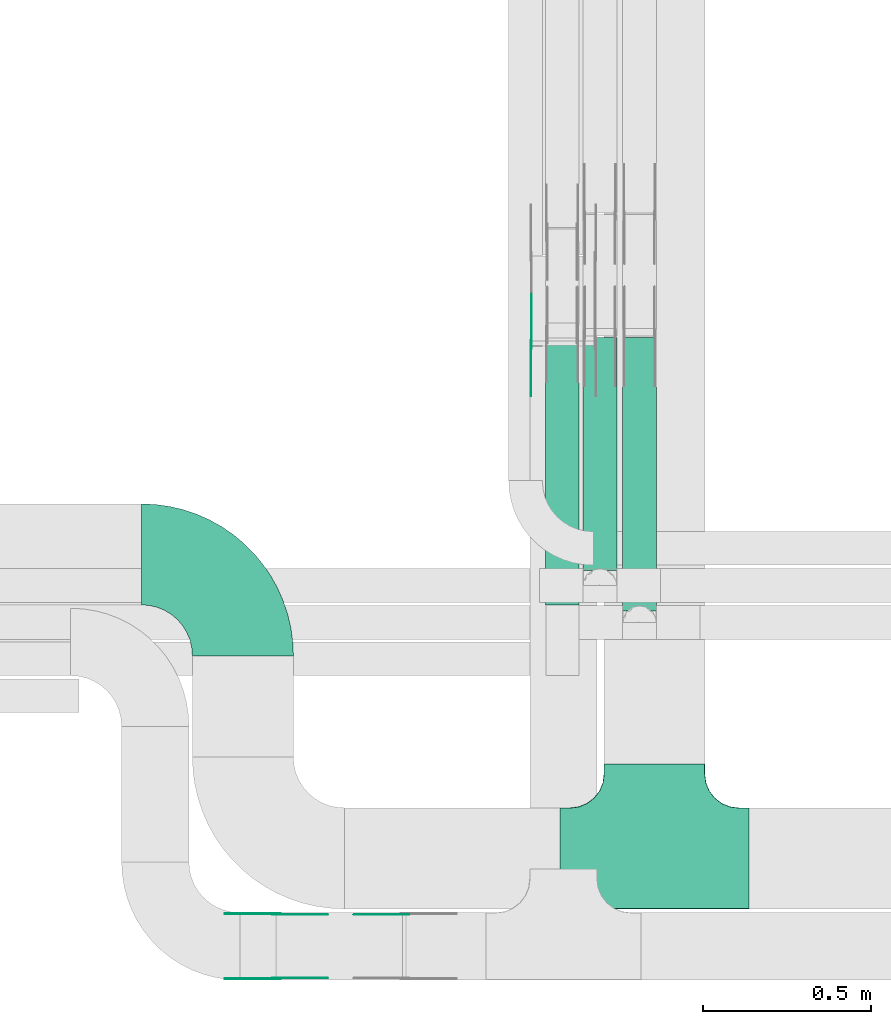
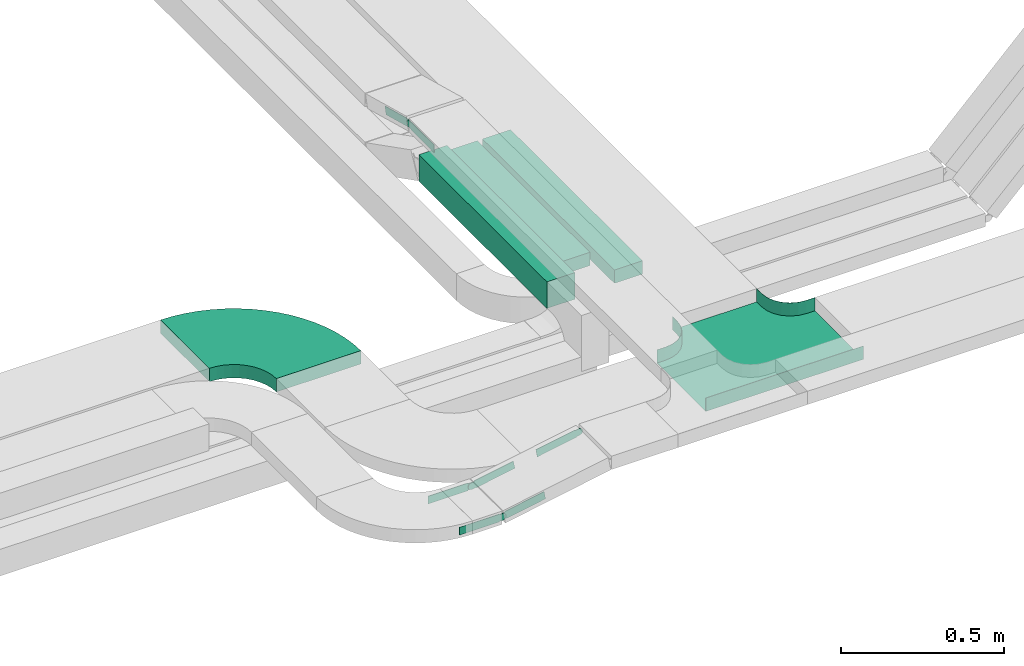
# One storey, part 14 of 19: 9 flow fittings, 3 flow segments.
"""IFC2X3 building model written with IfcOpenShell, lengths in millimetres."""

from ifc_helpers import new_model, entity, si_unit, converted_unit, derived_unit, direction, frame, frame_2d, origin, origin_2d_with_axis, place, context, subcontext, project, spatial, polyline, circle_curve, parameter, trimmed, segment, composite_curve, rectangle, outline, extrude, faceted_brep, source, transform, mapped, material, type_object, type_shapes, element, save


model = new_model("IFC2X3")

# Units and contexts
model_context = context("Model", 3, precision=0.01, world=origin(), true_north=direction((6.12303176911189e-17, 1.0)))
body_context = subcontext(model_context, "Body", "Model", "MODEL_VIEW")
ifc_project = project(units=[si_unit("LENGTHUNIT", "METRE", prefix="MILLI"), si_unit("AREAUNIT", "SQUARE_METRE"), si_unit("VOLUMEUNIT", "CUBIC_METRE"), converted_unit("PLANEANGLEUNIT", "DEGREE", entity("IfcRatioMeasure", 0.0174532925199433), si_unit("PLANEANGLEUNIT", "RADIAN"), dimensions=[0, 0, 0, 0, 0, 0, 0]), si_unit("MASSUNIT", "GRAM", prefix="KILO"), derived_unit("MASSDENSITYUNIT", [(si_unit("MASSUNIT", "GRAM", prefix="KILO"), 1), (si_unit("LENGTHUNIT", "METRE"), -3)]), derived_unit("MOMENTOFINERTIAUNIT", [(si_unit("LENGTHUNIT", "METRE"), 4)]), si_unit("TIMEUNIT", "SECOND"), si_unit("FREQUENCYUNIT", "HERTZ"), si_unit("THERMODYNAMICTEMPERATUREUNIT", "DEGREE_CELSIUS"), derived_unit("THERMALTRANSMITTANCEUNIT", [(si_unit("MASSUNIT", "GRAM", prefix="KILO"), 1), (si_unit("THERMODYNAMICTEMPERATUREUNIT", "KELVIN"), -1), (si_unit("TIMEUNIT", "SECOND"), -3)]), derived_unit("VOLUMETRICFLOWRATEUNIT", [(si_unit("LENGTHUNIT", "METRE"), 3), (si_unit("TIMEUNIT", "SECOND"), -1)]), derived_unit("MASSFLOWRATEUNIT", [(si_unit("MASSUNIT", "GRAM", prefix="KILO"), 1), (si_unit("TIMEUNIT", "SECOND"), -1)]), derived_unit("ROTATIONALFREQUENCYUNIT", [(si_unit("TIMEUNIT", "SECOND"), -1)]), si_unit("ELECTRICCURRENTUNIT", "AMPERE"), si_unit("ELECTRICVOLTAGEUNIT", "VOLT"), si_unit("POWERUNIT", "WATT"), si_unit("FORCEUNIT", "NEWTON", prefix="KILO"), si_unit("ILLUMINANCEUNIT", "LUX"), si_unit("LUMINOUSFLUXUNIT", "LUMEN"), si_unit("LUMINOUSINTENSITYUNIT", "CANDELA"), derived_unit("USERDEFINED", [(si_unit("MASSUNIT", "GRAM", prefix="KILO"), -1), (si_unit("LENGTHUNIT", "METRE"), -2), (si_unit("TIMEUNIT", "SECOND"), 3), (si_unit("LUMINOUSFLUXUNIT", "LUMEN"), 1)]), derived_unit("LINEARVELOCITYUNIT", [(si_unit("LENGTHUNIT", "METRE"), 1), (si_unit("TIMEUNIT", "SECOND"), -1)]), si_unit("PRESSUREUNIT", "PASCAL"), derived_unit("USERDEFINED", [(si_unit("LENGTHUNIT", "METRE"), -2), (si_unit("MASSUNIT", "GRAM", prefix="KILO"), 1), (si_unit("TIMEUNIT", "SECOND"), -2)]), derived_unit("LINEARFORCEUNIT", [(si_unit("MASSUNIT", "GRAM", prefix="KILO"), 1), (si_unit("LENGTHUNIT", "METRE"), 1), (si_unit("TIMEUNIT", "SECOND"), -2), (si_unit("LENGTHUNIT", "METRE"), -1)]), derived_unit("PLANARFORCEUNIT", [(si_unit("MASSUNIT", "GRAM", prefix="KILO"), 1), (si_unit("LENGTHUNIT", "METRE"), 1), (si_unit("TIMEUNIT", "SECOND"), -2), (si_unit("LENGTHUNIT", "METRE"), -2)])], contexts=[model_context])

# Site, building, storey
site_placement = place(None, origin())
site = spatial("IfcSite", under=ifc_project, at=site_placement, CompositionType="ELEMENT")
building_placement = place(site_placement, origin())
building = spatial("IfcBuilding", under=site, at=building_placement, CompositionType="ELEMENT")
storey_placement = place(building_placement, frame((0.0, 0.0, 12000.0)))
storey = spatial("IfcBuildingStorey", under=building, at=storey_placement, CompositionType="ELEMENT", Elevation=12000.0)

# Flow segments
cable_carrier_segment_type = type_object("IfcCableCarrierSegmentType", PredefinedType="CABLETRAYSEGMENT")
flow_segment_1_placement = place(storey_placement, frame((60138.97, 9727.13, 2655.0)))
element("IfcFlowSegment", 1, at=flow_segment_1_placement, inside=storey, type_object=cable_carrier_segment_type, context=body_context, shape_type="SweptSolid", body=[
    extrude(rectangle(XDim=788.027884581207, YDim=99.9999999999946, at=origin_2d_with_axis()), frame((50.0, 394.01, 0.0), z_axis=(0.0, 0.0, 1.0), x_axis=(0.0, -1.0, 0.0)), (0.0, 0.0, 1.0), 100.000000000001),
])
flow_segment_2_placement = place(storey_placement, frame((60250.78, 9829.12, 2680.0)))
element("IfcFlowSegment", 2, at=flow_segment_2_placement, inside=storey, type_object=cable_carrier_segment_type, context=body_context, shape_type="SweptSolid", body=[
    extrude(rectangle(XDim=692.037715986748, YDim=99.9999999999946, at=origin_2d_with_axis()), frame((50.0, 346.02, 0.0), z_axis=(0.0, 0.0, 1.0), x_axis=(0.0, -1.0, 0.0)), (0.0, 0.0, 1.0), 50.0000000000016),
])
flow_segment_3_placement = place(storey_placement, frame((60368.35, 9709.12, 2680.0)))
element("IfcFlowSegment", 3, at=flow_segment_3_placement, inside=storey, type_object=cable_carrier_segment_type, context=body_context, shape_type="SweptSolid", body=[
    extrude(rectangle(XDim=812.037715986744, YDim=99.9999999999946, at=origin_2d_with_axis()), frame((50.0, 406.02, 0.0), z_axis=(0.0, 0.0, 1.0), x_axis=(0.0, -1.0, 0.0)), (0.0, 0.0, 1.0), 50.0000000000016),
])

# Flow fittings
ifc_material_1 = material()
cable_carrier_fitting_type_1 = type_object("IfcCableCarrierFittingType", PredefinedType="NOTDEFINED", material=ifc_material_1)
shared_shape_1 = source(origin(), body_context, "Body", "Brep", [
    faceted_brep([(-153.41, -224.12, 25.0), (-150.0, -250.0, 25.0), (-150.0, -280.0, 25.0), (-149.2, -280.0, 25.0), (-149.2, -250.0, 25.0), (-152.63, -223.91, 25.0), (-162.7, -199.6, 25.0), (-178.72, -178.72, 25.0), (-199.6, -162.7, 25.0), (-223.91, -152.63, 25.0), (-250.0, -149.2, 25.0), (-280.0, -149.2, 25.0), (-280.0, -150.0, 25.0), (-250.0, -150.0, 25.0), (-224.12, -153.41, 25.0), (-200.0, -163.4, 25.0), (-179.29, -179.29, 25.0), (-163.4, -200.0, 25.0), (280.0, -150.0, 25.0), (280.0, -149.2, 25.0), (250.0, -149.2, 25.0), (223.91, -152.63, 25.0), (199.6, -162.7, 25.0), (178.72, -178.72, 25.0), (162.7, -199.6, 25.0), (152.63, -223.91, 25.0), (149.2, -250.0, 25.0), (149.2, -280.0, 25.0), (150.0, -280.0, 25.0), (150.0, -250.0, 25.0), (153.41, -224.12, 25.0), (163.4, -200.0, 25.0), (179.29, -179.29, 25.0), (200.0, -163.4, 25.0), (224.12, -153.41, 25.0), (250.0, -150.0, 25.0), (280.0, 149.2, 25.0), (280.0, 150.0, 25.0), (-280.0, 150.0, 25.0), (-280.0, 149.2, 25.0), (-280.0, -150.0, -25.0), (-280.0, 150.0, -25.0), (280.0, 150.0, -25.0), (280.0, -150.0, -25.0), (250.0, -150.0, -25.0), (224.12, -153.41, -25.0), (200.0, -163.4, -25.0), (179.29, -179.29, -25.0), (163.4, -200.0, -25.0), (153.41, -224.12, -25.0), (150.0, -250.0, -25.0), (150.0, -280.0, -25.0), (-150.0, -280.0, -25.0), (-150.0, -250.0, -25.0), (-153.41, -224.12, -25.0), (-163.4, -200.0, -25.0), (-179.29, -179.29, -25.0), (-200.0, -163.4, -25.0), (-224.12, -153.41, -25.0), (-250.0, -150.0, -25.0), (-150.0, -250.0, -24.2), (149.2, -280.0, -24.2), (-149.2, -280.0, -24.2), (-149.2, -250.0, -24.2), (-250.0, -149.2, -24.2), (-280.0, -149.2, -24.2), (280.0, -149.2, -24.2), (250.0, -149.2, -24.2), (-280.0, 149.2, -24.2), (-250.0, -150.0, -24.2), (250.0, -150.0, -24.2), (280.0, 149.2, -24.2), (149.2, -250.0, -24.2), (150.0, -250.0, -24.2), (-223.91, -152.63, -24.2), (-199.6, -162.7, -24.2), (-178.72, -178.72, -24.2), (-162.7, -199.6, -24.2), (-152.63, -223.91, -24.2), (152.63, -223.91, -24.2), (162.7, -199.6, -24.2), (178.72, -178.72, -24.2), (199.6, -162.7, -24.2), (223.91, -152.63, -24.2)], [[[0, 1, 2, 3, 4, 5, 6, 7, 8, 9, 10, 11, 12, 13, 14, 15, 16, 17]], [[18, 19, 20, 21, 22, 23, 24, 25, 26, 27, 28, 29, 30, 31, 32, 33, 34, 35]], [[36, 37, 38, 39]], [[40, 41, 42, 43, 44, 45, 46, 47, 48, 49, 50, 51, 52, 53, 54, 55, 56, 57, 58, 59]], [[2, 1, 60, 53, 52]], [[3, 2, 52, 51, 28, 27, 61, 62]], [[4, 3, 62, 63]], [[11, 10, 64, 65]], [[20, 19, 66, 67]], [[39, 38, 41, 40, 12, 11, 65, 68]], [[13, 12, 40, 59, 69]], [[18, 35, 70, 44, 43]], [[19, 18, 43, 42, 37, 36, 71, 66]], [[27, 26, 72, 61]], [[29, 28, 51, 50, 73]], [[38, 37, 42, 41]], [[36, 39, 68, 71]], [[68, 65, 64, 74, 75, 76, 77, 78, 63, 62, 61, 72, 79, 80, 81, 82, 83, 67, 66, 71]], [[14, 13, 69, 59, 58]], [[58, 57, 15, 14]], [[15, 57, 56, 16]], [[0, 17, 55, 54]], [[0, 54, 53, 60, 1]], [[55, 17, 16, 56]], [[5, 4, 63, 78]], [[6, 5, 78, 77]], [[7, 6, 77, 76]], [[8, 7, 76, 75]], [[9, 8, 75, 74]], [[10, 9, 74, 64]], [[21, 20, 67, 83]], [[22, 21, 83, 82]], [[23, 22, 82, 81]], [[81, 80, 24, 23]], [[24, 80, 79, 25]], [[79, 72, 26, 25]], [[30, 29, 73, 50, 49]], [[31, 30, 49, 48]], [[31, 48, 47, 32]], [[33, 32, 47, 46]], [[45, 34, 33, 46]], [[34, 45, 44, 70, 35]]]),
])
type_shapes(cable_carrier_fitting_type_1, [shared_shape_1])
flow_fitting_1_placement = place(storey_placement, frame((60462.55, 8974.99, 2825.0), z_axis=(0.0, 0.0, 1.0), x_axis=(-1.0, 0.0, 0.0)))
element("IfcFlowFitting", 4, at=flow_fitting_1_placement, inside=storey, type_object=cable_carrier_fitting_type_1, material=ifc_material_1, Name="470_DKC_S5_T", context=body_context, shape_type="MappedRepresentation", body=[
    mapped(shared_shape_1, transform((0.0, 0.0, 0.0), scale=1.0)),
])
cable_carrier_fitting_type_2 = type_object("IfcCableCarrierFittingType", Name="470_DKC_S5_Variable Angle Elbow 0-45:-", PredefinedType="NOTDEFINED", material=ifc_material_1)
shared_shape_2 = source(origin(), body_context, "Body", "SweptSolid", [
    extrude(outline(composite_curve([segment(polyline([(-150.75, -300.25), (-149.75, -300.25)]), True, "CONTINUOUS"), segment(trimmed(circle_curve(frame_2d((-149.75, 149.75), x_axis=(0.0, -1.0)), 450.0), [parameter(0.0)], [parameter(90.0000000000001)], True, "PARAMETER"), True, "CONTINUOUS"), segment(polyline([(300.25, 149.75), (300.25, 150.75)]), True, "CONTINUOUS"), segment(polyline([(300.25, 150.75), (0.25, 150.75)]), True, "CONTINUOUS"), segment(polyline([(0.25, 150.75), (0.25, 149.75)]), True, "CONTINUOUS"), segment(trimmed(circle_curve(frame_2d((-149.75, 149.75), x_axis=(0.0, -1.0)), 150.0), [parameter(0.0)], [parameter(90.0000000000001)], True, "PARAMETER"), False, "CONTINUOUS"), segment(polyline([(-149.75, -0.25), (-150.75, -0.25)]), True, "CONTINUOUS"), segment(polyline([(-150.75, -0.25), (-150.75, -300.25)]), True, "CONTINUOUS")], self_intersect=False)), frame((-150.25, 150.25, -25.0)), (0.0, 0.0, 1.0), 49.9999999999974),
])
type_shapes(cable_carrier_fitting_type_2, [shared_shape_2])
flow_fitting_2_placement = place(storey_placement, frame((59240.89, 9877.13, 2825.0), z_axis=(0.0, 0.0, 1.0), x_axis=(0.0, 1.0, 0.0)))
element("IfcFlowFitting", 5, at=flow_fitting_2_placement, inside=storey, type_object=cable_carrier_fitting_type_2, material=ifc_material_1, Name="470_DKC_S5_Variable Angle Elbow 0-45:-", ObjectType="470_DKC_S5_Variable Angle Elbow 0-45:-", context=body_context, shape_type="MappedRepresentation", body=[
    mapped(shared_shape_2, transform((0.0, 0.0, 0.0), scale=1.0)),
])
ifc_material_2 = material(Name="G")
cable_carrier_fitting_type_3 = type_object("IfcCableCarrierFittingType", PredefinedType="NOTDEFINED", material=ifc_material_2)
shared_shape_3 = source(origin(), body_context, "Body", "SweptSolid", [
    extrude(outline(composite_curve([segment(trimmed(circle_curve(frame_2d((-44.59, 0.0), x_axis=(1.0, 0.0)), 12.5), [parameter(90.0000000000007)], [parameter(270.0)], True, "PARAMETER"), True, "CONTINUOUS"), segment(polyline([(-44.59, -12.5), (-33.09, -12.5)]), True, "CONTINUOUS"), segment(polyline([(-33.09, -12.5), (-31.23, -14.5)]), True, "CONTINUOUS"), segment(polyline([(-31.23, -14.5), (108.91, -14.5)]), True, "CONTINUOUS"), segment(polyline([(108.91, -14.5), (108.91, 14.5)]), True, "CONTINUOUS"), segment(polyline([(108.91, 14.5), (-31.23, 14.5)]), True, "CONTINUOUS"), segment(polyline([(-31.23, 14.5), (-33.09, 12.5)]), True, "CONTINUOUS"), segment(polyline([(-33.09, 12.5), (-44.59, 12.5)]), True, "CONTINUOUS")], self_intersect=False)), frame((44.59, 0.0, 0.0), z_axis=(0.0, 0.0, -1.0), x_axis=(1.0, 0.0, 0.0)), (0.0, 0.0, -1.0), 2.0),
])
type_shapes(cable_carrier_fitting_type_3, [shared_shape_3])
flow_fitting_3_placement = place(storey_placement, frame((60099.09, 10499.75, 2895.0), z_axis=(-1.0, 0.0, 0.0), x_axis=(0.0, 0.965925826289068, -0.258819045102521)))
element("IfcFlowFitting", 6, at=flow_fitting_3_placement, inside=storey, type_object=cable_carrier_fitting_type_3, material=ifc_material_2, context=body_context, shape_type="MappedRepresentation", body=[
    mapped(shared_shape_3, transform((0.0, 0.0, 0.0), scale=1.0)),
])
cable_carrier_fitting_type_4 = type_object("IfcCableCarrierFittingType", PredefinedType="NOTDEFINED", material=ifc_material_2)
type_shapes(cable_carrier_fitting_type_4, [shared_shape_3])
flow_fitting_4_placement = place(storey_placement, frame((59340.89, 8809.28, 2825.0), z_axis=(0.0, 1.0, 0.0), x_axis=(-1.0, 0.0, 0.0)))
element("IfcFlowFitting", 7, at=flow_fitting_4_placement, inside=storey, type_object=cable_carrier_fitting_type_4, material=ifc_material_2, context=body_context, shape_type="MappedRepresentation", body=[
    mapped(shared_shape_3, transform((0.0, 0.0, 0.0), scale=1.0)),
])
flow_fitting_5_placement = place(storey_placement, frame((59340.89, 8620.36, 2825.0), z_axis=(0.0, -1.0, 0.0), x_axis=(0.98359332593576, 0.0, 0.180400025428575)))
element("IfcFlowFitting", 8, at=flow_fitting_5_placement, inside=storey, type_object=cable_carrier_fitting_type_3, material=ifc_material_2, context=body_context, shape_type="MappedRepresentation", body=[
    mapped(shared_shape_3, transform((0.0, 0.0, 0.0), scale=1.0)),
])
cable_carrier_fitting_type_5 = type_object("IfcCableCarrierFittingType", PredefinedType="NOTDEFINED", material=ifc_material_2)
shared_shape_4 = source(origin(), body_context, "Body", "SweptSolid", [
    extrude(outline(composite_curve([segment(trimmed(circle_curve(frame_2d((-44.59, 0.0), x_axis=(1.0, 0.0)), 12.5), [parameter(90.0000000000007)], [parameter(270.0)], True, "PARAMETER"), True, "CONTINUOUS"), segment(polyline([(-44.59, -12.5), (-33.09, -12.5)]), True, "CONTINUOUS"), segment(polyline([(-33.09, -12.5), (-31.23, -14.5)]), True, "CONTINUOUS"), segment(polyline([(-31.23, -14.5), (108.91, -14.5)]), True, "CONTINUOUS"), segment(polyline([(108.91, -14.5), (108.91, 14.5)]), True, "CONTINUOUS"), segment(polyline([(108.91, 14.5), (-31.23, 14.5)]), True, "CONTINUOUS"), segment(polyline([(-31.23, 14.5), (-33.09, 12.5)]), True, "CONTINUOUS"), segment(polyline([(-33.09, 12.5), (-44.59, 12.5)]), True, "CONTINUOUS")], self_intersect=False)), frame((44.59, 0.0, 0.0)), (0.0, 0.0, 1.0), 2.0),
])
type_shapes(cable_carrier_fitting_type_5, [shared_shape_4])
flow_fitting_6_placement = place(storey_placement, frame((60097.09, 10499.75, 2895.0), z_axis=(-1.0, 0.0, 0.0), x_axis=(0.0, -1.0, 0.0)))
element("IfcFlowFitting", 9, at=flow_fitting_6_placement, inside=storey, type_object=cable_carrier_fitting_type_5, material=ifc_material_2, context=body_context, shape_type="MappedRepresentation", body=[
    mapped(shared_shape_4, transform((0.0, 0.0, 0.0), scale=1.0)),
])
cable_carrier_fitting_type_6 = type_object("IfcCableCarrierFittingType", PredefinedType="NOTDEFINED", material=ifc_material_2)
type_shapes(cable_carrier_fitting_type_6, [shared_shape_4])
flow_fitting_7_placement = place(storey_placement, frame((59722.55, 8807.28, 2895.0), z_axis=(0.0, 1.0, 0.0), x_axis=(-0.983593325935759, 0.0, -0.180400025428576)))
element("IfcFlowFitting", 10, at=flow_fitting_7_placement, inside=storey, type_object=cable_carrier_fitting_type_6, material=ifc_material_2, context=body_context, shape_type="MappedRepresentation", body=[
    mapped(shared_shape_4, transform((0.0, 0.0, 0.0), scale=1.0)),
])
flow_fitting_8_placement = place(storey_placement, frame((59340.89, 8618.36, 2825.0), z_axis=(0.0, -1.0, 0.0), x_axis=(-1.0, 0.0, 0.0)))
element("IfcFlowFitting", 11, at=flow_fitting_8_placement, inside=storey, type_object=cable_carrier_fitting_type_5, material=ifc_material_2, context=body_context, shape_type="MappedRepresentation", body=[
    mapped(shared_shape_4, transform((0.0, 0.0, 0.0), scale=1.0)),
])
flow_fitting_9_placement = place(storey_placement, frame((59340.89, 8807.28, 2825.0), z_axis=(0.0, 1.0, 0.0), x_axis=(0.98359332593576, 0.0, 0.180400025428575)))
element("IfcFlowFitting", 12, at=flow_fitting_9_placement, inside=storey, type_object=cable_carrier_fitting_type_6, material=ifc_material_2, context=body_context, shape_type="MappedRepresentation", body=[
    mapped(shared_shape_4, transform((0.0, 0.0, 0.0), scale=1.0)),
])

save(model, "model.ifc")
